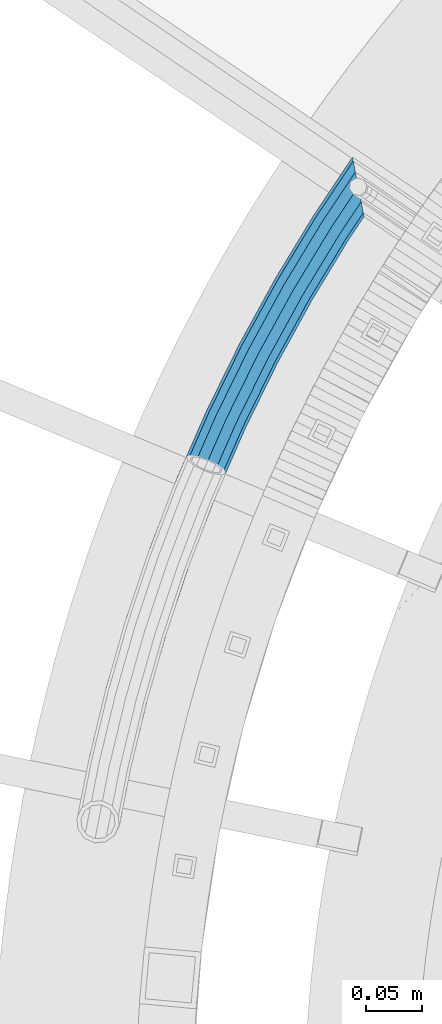
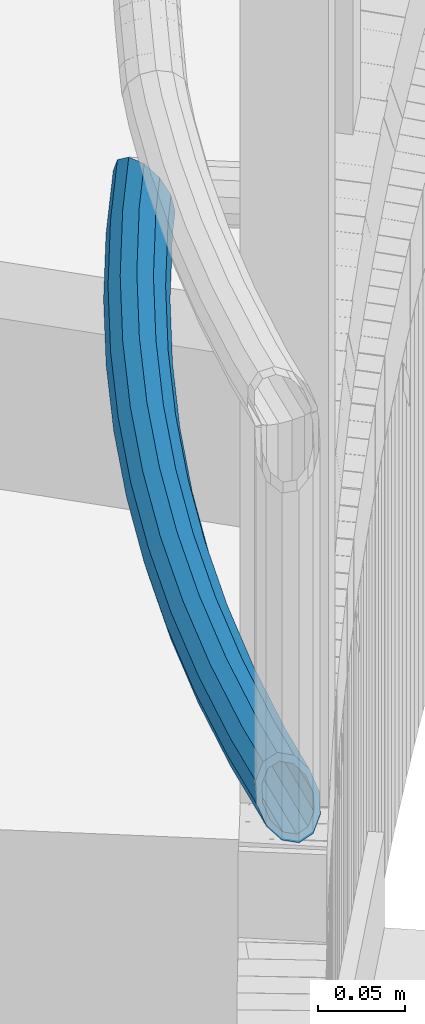
# One storey, part 477 of 975: 1 beam.
"""IFC2X3 building model written with IfcOpenShell, lengths in millimetres."""

import ifcopenshell
import ifcopenshell.guid

model = None  # the IFC model being written
_history = None  # IfcOwnerHistory: only IFC2X3 demands one
_inside = {}  # id of a spatial element -> (the spatial element, [elements in it])
_under = {}  # id of a project, library or spatial element -> (it, [spatial elements below it])
_declared = {}  # id of a project -> (the project, [libraries it declares])
_typed = {}  # id of a type object -> (the type object, [elements of that type])
_made_of = {}  # id of a material, layer set ... -> (it, [elements and type objects made of it])


def new_model(schema):
    """Start an empty IFC model of exactly this schema.

    Asked for "IFC4X3", IfcOpenShell would pick the latest addendum, in which some entities
    have other attributes; the version numbers below select the first issue.
    IFC2X3 requires an IfcOwnerHistory on every rooted entity: one is made here for all.
    """
    global model, _history
    if schema == "IFC4X3":
        model = ifcopenshell.file(schema_version=(4, 3, 0, 0))
    else:
        model = ifcopenshell.file(schema=schema)
    _inside.clear()
    _under.clear()
    _declared.clear()
    _typed.clear()
    _made_of.clear()
    _history = None
    if model.schema == "IFC2X3":
        org = make("IfcOrganization", Name="unknown")
        user = make(
            "IfcPersonAndOrganization",
            ThePerson=make("IfcPerson", FamilyName="unknown"),
            TheOrganization=org,
        )
        app = make(
            "IfcApplication",
            ApplicationDeveloper=org,
            Version="unknown",
            ApplicationFullName="unknown",
            ApplicationIdentifier="unknown",
        )
        _history = make(
            "IfcOwnerHistory",
            OwningUser=user,
            OwningApplication=app,
            ChangeAction="ADDED",
            CreationDate=0,
        )
    return model


def make(cls, **values):
    """One entity of the class cls with the attributes given. An attribute that is None is left unset."""
    return model.create_entity(
        cls, **{name: value for name, value in values.items() if value is not None}
    )


def rooted(cls, **values):
    """An entity with a GlobalId (a new one), such as an element, a storey or a relation."""
    return make(cls, GlobalId=ifcopenshell.guid.new(), OwnerHistory=_history, **values)


def si_unit(unit_type, name, prefix=None):
    """IfcSIUnit, for example si_unit("LENGTHUNIT", "METRE", prefix="MILLI")."""
    return make("IfcSIUnit", UnitType=unit_type, Prefix=prefix, Name=name)


def assignment(units):
    """IfcUnitAssignment: the units of a project."""
    return None if units is None else make("IfcUnitAssignment", Units=units)


def point(xyz):
    """IfcCartesianPoint."""
    return None if xyz is None else make("IfcCartesianPoint", Coordinates=xyz)


def direction(xyz):
    """IfcDirection."""
    return None if xyz is None else make("IfcDirection", DirectionRatios=xyz)


def frame(location, z_axis=None, x_axis=None):
    """IfcAxis2Placement3D, a coordinate frame: its origin and axes. An axis left out is left unset."""
    return make(
        "IfcAxis2Placement3D",
        Location=point(location),
        Axis=direction(z_axis),
        RefDirection=direction(x_axis),
    )


def origin_with_axes():
    """The frame at (0, 0, 0) with the z axis (0, 0, 1) and the x axis (1, 0, 0) written out."""
    return frame((0.0, 0.0, 0.0), z_axis=(0.0, 0.0, 1.0), x_axis=(1.0, 0.0, 0.0))


def place(relative_to, where):
    """IfcLocalPlacement: puts the frame where relative to a parent placement (None: the world)."""
    return make(
        "IfcLocalPlacement", PlacementRelTo=relative_to, RelativePlacement=where
    )


def context(
    kind, dimensions, precision=None, world=None, true_north=None, identifier=None
):
    """IfcGeometricRepresentationContext, for example the 3D "Model" context."""
    return make(
        "IfcGeometricRepresentationContext",
        ContextIdentifier=identifier,
        ContextType=kind,
        CoordinateSpaceDimension=dimensions,
        Precision=precision,
        WorldCoordinateSystem=world,
        TrueNorth=true_north,
    )


def subcontext(parent, identifier, kind, view, scale=None):
    """IfcGeometricRepresentationSubContext, for example "Body" below "Model"."""
    return make(
        "IfcGeometricRepresentationSubContext",
        ContextIdentifier=identifier,
        ContextType=kind,
        ParentContext=parent,
        TargetScale=scale,
        TargetView=view,
    )


def project(units=None, contexts=None):
    """IfcProject with its units and contexts."""
    return rooted(
        "IfcProject",
        Name="project",
        RepresentationContexts=contexts,
        UnitsInContext=assignment(units),
    )


def spatial(cls, under=None, at=None, **own):
    """A site, building, storey or space (cls), placed at a placement, below another one or the project."""
    s = rooted(cls, ObjectPlacement=at, **own)
    if under is not None:
        _under.setdefault(under.id(), (under, []))[1].append(s)
    return s


def faces_of(points, faces, orient=None, outer=None):
    """IfcFace entities. A face is a list of loops; a loop is a list of indices into points, from 0.

    orient and outer hold one flag for each loop. By default every Orientation is true, the
    first loop of a face is its IfcFaceOuterBound and the others are IfcFaceBound.
    """
    made = []
    for i, loops in enumerate(faces):
        bounds = []
        for j, loop in enumerate(loops):
            is_outer = j == 0 if outer is None else outer[i][j]
            bounds.append(
                make(
                    "IfcFaceOuterBound" if is_outer else "IfcFaceBound",
                    Bound=make("IfcPolyLoop", Polygon=[points[k] for k in loop]),
                    Orientation=True if orient is None else orient[i][j],
                )
            )
        made.append(make("IfcFace", Bounds=bounds))
    return made


def faceted_brep(points, faces, orient=None, outer=None, voids=None):
    """IfcFacetedBrep: a solid bounded by flat faces; with voids (closed shells), ...WithVoids."""
    shared = [point(p) for p in points]
    hull = make("IfcClosedShell", CfsFaces=faces_of(shared, faces, orient, outer))
    if voids is None:
        return make("IfcFacetedBrep", Outer=hull)
    return make(
        "IfcFacetedBrepWithVoids",
        Outer=hull,
        Voids=[
            make(cls, CfsFaces=faces_of(shared, fs, o, b)) for cls, fs, o, b in voids
        ],
    )


def shape(context_of_items, identifier, shape_type, items):
    """IfcShapeRepresentation: the items that make up one representation, for example the "Body"."""
    return make(
        "IfcShapeRepresentation",
        ContextOfItems=context_of_items,
        RepresentationIdentifier=identifier,
        RepresentationType=shape_type,
        Items=items,
    )


def material(Name=None, Category=None):
    """IfcMaterial."""
    return make("IfcMaterial", Name=Name, Category=Category)


def made_of(thing, what):
    """Note that an element or type object is made of a material, layer set ...; save() writes the relation."""
    if what is not None:
        _made_of.setdefault(what.id(), (what, []))[1].append(thing)
    return thing


def type_object(cls, material=None, **own):
    """A type object (cls), such as IfcWallType, which elements share."""
    return made_of(rooted(cls, **own), material)


def element(
    cls,
    number,
    at=None,
    inside=None,
    cuts=None,
    type_object=None,
    material=None,
    context=None,
    identifier="Body",
    shape_type=None,
    held_by="IfcProductDefinitionShape",
    body=None,
    shapes=None,
    **own,
):
    """One element of the class cls, such as IfcWall. Its Tag is "e" and its number.

    at: its placement. inside: the storey or other place that contains it. cuts: it is an
    opening in that element (IfcRelVoidsElement). A single representation is given by context,
    identifier, shape_type and body (its items); several are given by shapes. held_by: the class
    of the entity that holds the representations. save() writes the other relations.
    """
    e = rooted(cls, Tag="e%d" % number, ObjectPlacement=at, **own)
    if body is not None:
        shapes = [shape(context, identifier, shape_type, body)]
    if shapes is not None:
        e.Representation = make(held_by, Representations=shapes)
    if inside is not None:
        _inside.setdefault(inside.id(), (inside, []))[1].append(e)
    if cuts is not None:
        rooted(
            "IfcRelVoidsElement", RelatingBuildingElement=cuts, RelatedOpeningElement=e
        )
    if type_object is not None:
        _typed.setdefault(type_object.id(), (type_object, []))[1].append(e)
    return made_of(e, material)


def aggregate(whole, parts):
    """IfcRelAggregates: a whole, such as a stair, and the parts it consists of."""
    return rooted("IfcRelAggregates", RelatingObject=whole, RelatedObjects=parts)


def save(model, path):
    """Write the relations noted so far, then the file.

    IfcRelAggregates (storeys below a building ...), IfcRelContainedInSpatialStructure (elements
    in a storey), IfcRelDefinesByType, IfcRelAssociatesMaterial and IfcRelDeclares: one each for
    every whole, place, type object, material and project.
    """
    for whole, parts in _under.values():
        aggregate(whole, parts)
    for where, things in _inside.values():
        rooted(
            "IfcRelContainedInSpatialStructure",
            RelatedElements=things,
            RelatingStructure=where,
        )
    for kind, things in _typed.values():
        rooted("IfcRelDefinesByType", RelatedObjects=things, RelatingType=kind)
    for what, things in _made_of.values():
        rooted("IfcRelAssociatesMaterial", RelatedObjects=things, RelatingMaterial=what)
    for by, libraries in _declared.values():
        rooted("IfcRelDeclares", RelatingContext=by, RelatedDefinitions=libraries)
    model.write(path)


model = new_model("IFC2X3")

# Units and contexts
model_context = context("Model", 3, precision=1e-05, world=origin_with_axes())
body_context = subcontext(model_context, "Body", "Model", "MODEL_VIEW")
ifc_project = project(units=[si_unit("LENGTHUNIT", "METRE", prefix="MILLI"), si_unit("AREAUNIT", "SQUARE_METRE"), si_unit("VOLUMEUNIT", "CUBIC_METRE"), si_unit("MASSUNIT", "GRAM", prefix="KILO"), si_unit("TIMEUNIT", "SECOND"), si_unit("PLANEANGLEUNIT", "RADIAN"), si_unit("SOLIDANGLEUNIT", "STERADIAN"), si_unit("THERMODYNAMICTEMPERATUREUNIT", "DEGREE_CELSIUS"), si_unit("LUMINOUSINTENSITYUNIT", "LUMEN")], contexts=[model_context])

# Site, building, storey
site_placement = place(None, origin_with_axes())
site = spatial("IfcSite", under=ifc_project, at=site_placement, CompositionType="ELEMENT")
building_placement = place(site_placement, origin_with_axes())
building = spatial("IfcBuilding", under=site, at=building_placement, Name="Undefined", CompositionType="ELEMENT")
storey_placement = place(building_placement, origin_with_axes())
storey = spatial("IfcBuildingStorey", under=building, at=storey_placement, Name="Undefined", CompositionType="ELEMENT", Elevation=0.0)

# Beam
ifc_material = material()
beam_type = type_object("IfcBeamType", PredefinedType="NOTDEFINED")
beam_placement = place(storey_placement, frame((33276.7534098657, 3656.66738124268, 628.65), z_axis=(-0.924359056186259, 0.381523702076881, 0.0), x_axis=(0.381523702076881, 0.924359056186259, 0.0)))
element("IfcBeam", 1, at=beam_placement, inside=storey, type_object=beam_type, material=ifc_material, Name="HANDRAIL", context=body_context, shape_type="Brep", body=[
    faceted_brep([(65.3637888262547, -16.4977839420935, 3.38205051437035), (66.5828862283506, -9.52499999999998, -3.48333493930113), (130.064114738725, -9.52499999999998, 6.35599401342552), (129.147726991516, -16.4977839420935, 13.2682982168153), (193.916236107083, -9.52499999999998, 13.3976816084796), (193.304326613952, -16.4977839420935, 20.3435640344615), (258.016017771459, -9.52499999999998, 17.62813761289), (257.709767498247, -16.4977839420935, 24.5941929294677), (322.239749193384, -9.52499999999998, 19.0391973812475), (322.239749193373, -16.4977839420935, 26.0119813233578), (386.463480615312, -9.52499999999998, 17.6281376130864), (386.769730888507, -16.4977839420935, 24.5941929296569), (450.563262279695, -9.52499999999998, 13.3976816088543), (451.175171772811, -16.4977839420935, 20.3435640348325), (514.415383648073, -9.52499999999998, 6.3559940139894), (515.331771395264, -16.4977839420935, 13.2682982173792), (577.896612158471, -9.52499999999998, -3.48333493855534), (579.115709560549, -16.4977839420935, 3.38205051512705), (514.079962452885, 0.0, 3.82591507686448), (577.450391539624, 0.0, -5.99624042137293), (450.339287860399, 0.0, 10.8553121892437), (386.351385235408, 0.0, 15.0783844030484), (322.239749193384, 0.0, 16.4869813233345), (258.128113151368, 0.0, 15.0783844028665), (194.140210526388, 0.0, 10.8553121888654), (130.399535933917, 0.0, 3.82591507630787), (67.0291068472052, 0.0, -5.99624042211872), (66.5828862283506, 9.52499999999998, -3.48333493930113), (130.064114738725, 9.52499999999998, 6.35599401342552), (193.916236107083, 9.52499999999998, 13.3976816084796), (258.016017771459, 9.52499999999998, 17.62813761289), (322.239749193384, 9.52499999999998, 19.0391973812475), (386.463480615312, 9.52499999999998, 17.6281376130864), (450.563262279695, 9.52499999999998, 13.3976816088543), (514.415383648073, 9.52499999999998, 6.3559940139894), (577.896612158471, 9.52499999999998, -3.48333493855534), (515.331771395264, 16.4977839420935, 13.2682982173792), (579.115709560549, 16.4977839420935, 3.38205051512705), (451.175171772811, 16.4977839420935, 20.3435640348325), (386.769730888507, 16.4977839420935, 24.5941929296569), (322.239749193373, 16.4977839420935, 26.0119813233578), (257.709767498247, 16.4977839420935, 24.5941929294677), (193.304326613952, 16.4977839420935, 20.3435640344615), (129.147726991516, 16.4977839420935, 13.2682982168153), (65.3637888262547, 16.4977839420935, 3.38205051437035), (2.63382389675826e-07, 19.0500000000138, 0.0), (-2.07561308872391, 16.4977839420935, 9.29609892945882), (62.0331527843518, 16.4977839420935, 22.1386323873594), (63.6984708053005, 19.05, 12.7603414508667), (2.07561308872391, 16.4977839420935, -9.29609892945882), (127.895918049117, 19.05, 22.7106813573264), (192.468442701516, 19.05, 29.8318158800575), (257.291421845126, 19.05, 34.1100014560689), (322.239749193363, 19.05, 35.5369813233847), (387.188076541603, 19.05, 34.1100014562617), (452.011055685223, 19.05, 29.8318158804359), (516.583580337643, 19.05, 22.7106813578939), (580.781027581477, 19.05, 12.760341451627), (517.835389280019, 16.4977839420935, 32.1530644984086), (582.44634560241, 16.4977839420935, 22.1386323881234), (452.846939597635, 16.4977839420935, 39.3200677260247), (387.606422194698, 16.4977839420935, 43.6258099828665), (322.239749193352, 16.4977839420935, 45.061981323408), (256.873076192007, 16.4977839420935, 43.62580998267), (191.632558789082, 16.4977839420935, 39.3200677256427), (126.644109106714, 16.4977839420935, 32.1530644978302), (60.8140553822523, 9.52499999999998, 29.0040178410381), (125.727721359504, 9.52499999999998, 39.06536870122), (191.020649295948, 9.52499999999998, 46.2659501516282), (256.566825918795, 9.52499999999998, 50.5918652992441), (322.239749193341, 9.52499999999998, 52.0347652655219), (387.912672467894, 9.52499999999998, 50.5918652994369), (453.458849090748, 9.52499999999998, 46.2659501520102), (518.751777027213, 9.52499999999998, 39.0653687017912), (583.665443004487, 9.52499999999998, 29.0040178418058), (519.087198222398, 0.0, 41.5954476389234), (584.111663623338, 0.0, 31.5169233246233), (453.682823510044, 0.0, 48.8083195716245), (388.024767847797, 0.0, 53.1416185094749), (322.239749193341, 0.0, 54.5869813234276), (256.454730538882, 0.0, 53.1416185092821), (190.796674876647, 0.0, 48.8083195712388), (125.392300164309, 0.0, 41.5954476383449), (60.3678347633977, 0.0, 31.5169233238521), (60.8140553822523, -9.52499999999998, 29.0040178410381), (125.727721359504, -9.52499999999998, 39.06536870122), (191.020649295948, -9.52499999999998, 46.2659501516282), (256.566825918795, -9.52499999999998, 50.5918652992441), (322.239749193341, -9.52499999999998, 52.0347652655219), (387.912672467894, -9.52499999999998, 50.5918652994369), (453.458849090748, -9.52499999999998, 46.2659501520102), (518.751777027213, -9.52499999999998, 39.0653687017912), (583.665443004487, -9.52499999999998, 29.0040178418058), (517.835389280019, -16.4977839420935, 32.1530644984086), (582.44634560241, -16.4977839420935, 22.1386323881234), (452.846939597635, -16.4977839420935, 39.3200677260247), (387.606422194698, -16.4977839420935, 43.6258099828665), (322.239749193352, -16.4977839420935, 45.061981323408), (256.873076192007, -16.4977839420935, 43.62580998267), (191.632558789082, -16.4977839420935, 39.3200677256427), (126.644109106714, -16.4977839420935, 32.1530644978302), (62.0331527843518, -16.4977839420935, 22.1386323873594), (63.6984708053005, -19.05, 12.7603414508667), (127.895918049117, -19.05, 22.7106813573264), (192.468442701516, -19.05, 29.8318158800575), (257.291421845126, -19.05, 34.1100014560689), (322.239749193363, -19.05, 35.5369813233847), (387.188076541603, -19.05, 34.1100014562617), (452.011055685223, -19.05, 29.8318158804359), (516.583580337643, -19.05, 22.7106813578939), (580.781027581477, -19.05, 12.760341451627), (623.525097919031, -19.05, 4.19767227600096), (634.804402413814, -16.4977839420935, 11.6500496299996), (643.061426378037, -9.52499999999998, 17.1055684903004), (646.083706908601, 0.0, 19.1024269839945), (643.061426378037, 9.52499999999998, 17.1055684903004), (634.804402413814, 16.4977839420935, 11.6500496299996), (623.525097919031, 19.05, 4.19767227600096), (612.245793424245, 16.4977839420935, -3.254705077994), (603.988769460022, 9.52499999999998, -8.7102239382948), (600.966488929462, 0.0, -10.7070824319962), (603.988769460022, -9.52499999999998, -8.7102239382948), (612.245793424245, -16.4977839420935, -3.254705077994), (30.790975576012, -19.05, 6.16817573464141), (30.3241337357649, -16.4977839420935, -3.63723829465016), (24.9767879872525, -9.52499999999998, -11.8180408322805), (16.181755305437, 0.0, -16.1821924448705), (6.29565759481557, 9.52499999999998, -15.5603222321697), (2.99239702710111, 12.2906573535938, -13.402121499068), (-1.99318286347625, 16.4977839420935, -10.2988858246208), (-6.50834134794059, 19.05, -1.60403212389792), (-6.06585272390294, 16.4977839420935, 8.3126728590214), (-2.96709431060299, 12.4067716602382, 13.2887976059719), (-0.757097620109562, 9.52499999999998, 16.6698295018068), (8.0379350617095, 0.0, 21.0339811143895), (17.924032772331, -9.52499999999998, 20.4121109016887), (26.2522236139012, -16.4977839420935, 14.9708484849871), (1.67432789157101, 13.3082123799554, -7.49885313643608), (0.710976735876102, 13.3082123799554, -7.73627863667934), (1.89139084506678, 12.3121092799737, -8.47101827673396), (2.12461600312963e-07, 15.3670000000093, 0.0), (-2.93125110825531, 15.367, -0.722429984769406), (-1.67432789157465, 13.3082123799554, 7.49885313643244), (-1.8753978715722, 12.3855011242308, 8.39939015654454), (-2.57431028486826, 13.3082123799554, 7.27704536812598), (63.6984708053005, 15.367, 12.7603414508667), (62.3551142684009, 13.3082123799554, 20.3254961396378), (61.3717090307091, 7.68349999999998, 25.8635737389341), (1.73051132193723, 7.68349999999998, 13.9160020361778), (61.0117577314977, 0.0, 27.890650828409), (8.82517101860321, 0.0, 17.4364176703311), (61.3717090307091, -7.68349999999998, 25.8635737389341), (16.7999565051687, -7.68349999999998, 16.9347756987518), (62.3551142684009, -13.3082123799554, 20.3254961396378), (23.5180304507048, -13.3082123799554, 12.5454906826089), (63.6984708053005, -15.367, 12.7603414508667), (27.1792903668047, -15.367, 5.44466799733345), (66.3851838791052, 0.0, -2.36996792668288), (66.0252325798974, 7.68349999999998, -0.342890837204322), (7.41973386197424, 7.68349999999998, -12.0829870292255), (15.3945193485433, 0.0, -12.5846290008121), (66.0252325798974, -7.68349999999998, -0.342890837204322), (22.4891790452093, -7.68349999999998, -9.06421336665517), (65.0418273422038, -13.3082123799554, 5.19518676209191), (26.8027046156749, -13.3082123799554, -2.46503265296269), (65.0418273422038, 13.3082123799554, 5.19518676209191), (128.905710595986, 13.3082123799554, 15.0938256239788), (127.895918049117, 15.367, 22.7106813573264), (126.886125502246, 13.3082123799554, 30.3275370906704), (126.146906052829, 7.68349999999998, 35.9034624814012), (125.876332955373, 0.0, 37.9443928240107), (126.146906052829, -7.68349999999998, 35.9034624814012), (126.886125502246, -13.3082123799554, 30.3275370906704), (127.895918049117, -15.367, 22.7106813573264), (128.905710595986, -13.3082123799554, 15.0938256239788), (129.644930045401, -7.68349999999998, 9.51790023324793), (129.915503142856, 0.0, 7.47696989063479), (129.644930045401, 7.68349999999998, 9.51790023324793), (193.636329382009, 7.68349999999998, 16.5749475676494), (193.142722390881, 13.3082123799554, 22.1779593912761), (192.468442701516, 15.367, 29.8318158800575), (191.794163012153, 13.3082123799554, 37.4856723688281), (191.300556021026, 7.68349999999998, 43.0886841924548), (191.11988332279, 0.0, 45.1395288576059), (191.300556021026, -7.68349999999998, 43.0886841924548), (191.794163012153, -13.3082123799554, 37.4856723688281), (192.468442701516, -15.367, 29.8318158800575), (193.142722390881, -13.3082123799554, 22.1779593912761), (193.636329382009, -7.68349999999998, 16.5749475676494), (193.817002080246, 0.0, 14.5241029024946), (257.96635283216, 0.0, 18.7578303664886), (257.875929225702, 7.68349999999998, 20.8146312892422), (257.628887338644, 13.3082123799554, 26.4339159112751), (257.291421845126, 15.367, 34.1100014560689), (256.953956351608, 13.3082123799554, 41.7860870008662), (256.70691446455, 7.68349999999998, 47.4053716228991), (256.61649085809, 0.0, 49.46217254566), (256.70691446455, -7.68349999999998, 47.4053716228991), (256.953956351608, -13.3082123799554, 41.7860870008662), (257.291421845126, -15.367, 34.1100014560689), (257.628887338644, -13.3082123799554, 26.4339159112751), (257.875929225702, -7.68349999999998, 20.8146312892422), (322.239749193381, -7.68349999999998, 22.2287689433906), (322.239749193381, 0.0, 20.1699813233427), (322.239749193381, 7.68349999999998, 22.2287689433906), (322.239749193373, 13.3082123799554, 27.8534813233637), (322.239749193363, 15.367, 35.5369813233847), (322.239749193355, 13.3082123799554, 43.2204813233984), (322.239749193344, 7.68349999999998, 48.8451937033751), (322.239749193344, 0.0, 50.9039813234194), (322.239749193344, -7.68349999999998, 48.8451937033751), (322.239749193355, -13.3082123799554, 43.2204813233984), (322.239749193363, -15.367, 35.5369813233847), (322.239749193373, -13.3082123799554, 27.8534813233637), (386.850611048107, -13.3082123799554, 26.4339159114606), (386.60356916106, -7.68349999999998, 20.8146312894351), (386.513145554607, 0.0, 18.7578303666705), (386.60356916106, 7.68349999999998, 20.8146312894351), (386.850611048107, 13.3082123799554, 26.4339159114606), (387.188076541603, 15.367, 34.1100014562617), (387.525542035102, 13.3082123799554, 41.7860870010554), (387.772583922142, 7.68349999999998, 47.4053716230883), (387.863007528602, 0.0, 49.4621725458528), (387.772583922142, -7.68349999999998, 47.4053716230883), (387.525542035102, -13.3082123799554, 41.7860870010554), (387.188076541603, -15.367, 34.1100014562617), (452.011055685223, -15.367, 29.8318158804359), (451.336775995878, -13.3082123799554, 22.1779593916544), (450.843169004766, -7.68349999999998, 16.5749475680241), (450.66249630653, 0.0, 14.524102902873), (450.843169004766, 7.68349999999998, 16.5749475680241), (451.336775995878, 13.3082123799554, 22.1779593916544), (452.011055685223, 15.367, 29.8318158804359), (452.685335374568, 13.3082123799554, 37.4856723692101), (453.178942365681, 7.68349999999998, 43.0886841928404), (453.359615063913, 0.0, 45.1395288579915), (453.178942365681, -7.68349999999998, 43.0886841928404), (452.685335374568, -13.3082123799554, 37.4856723692101), (517.593372884494, -13.3082123799554, 30.3275370912379), (516.583580337643, -15.367, 22.7106813578939), (515.573787790792, -13.3082123799554, 15.0938256245427), (514.83456834139, -7.68349999999998, 9.51790023381545), (514.563995243938, 0.0, 7.47696989119868), (514.83456834139, 7.68349999999998, 9.51790023381545), (515.573787790792, 13.3082123799554, 15.0938256245427), (516.583580337643, 15.367, 22.7106813578939), (517.593372884494, 13.3082123799554, 30.3275370912379), (518.332592333896, 7.68349999999998, 35.9034624819724), (518.603165431345, 0.0, 37.9443928245892), (518.332592333896, -7.68349999999998, 35.9034624819724), (583.10778935604, -7.68349999999998, 25.8635737397053), (582.124384118364, -13.3082123799554, 20.3254961404018), (580.781027581477, -15.367, 12.760341451627), (579.437671044598, -13.3082123799554, 5.19518676284861), (578.454265806919, -7.68349999999998, -0.342890836451261), (578.094314507714, 0.0, -2.36996792592618), (578.454265806919, 7.68349999999998, -0.342890836451261), (579.437671044598, 13.3082123799554, 5.19518676284861), (580.781027581477, 15.367, 12.760341451627), (582.124384118364, 13.3082123799554, 20.3254961404018), (583.10778935604, 7.68349999999998, 25.8635737397053), (583.467740655247, 0.0, 27.8906508291766), (641.722375837286, 0.0, 16.2208410737876), (639.284402875965, -7.68349999999998, 14.6100418888745), (632.623736878159, -13.3082123799554, 10.2092566748906), (623.525097919031, -15.367, 4.19767227600096), (614.426458959904, -13.3082123799554, -1.81391212288509), (607.765792962098, -7.68349999999998, -6.21469733686536), (605.327820000777, 0.0, -7.8254965217784), (607.765792962098, 7.68349999999998, -6.21469733686536), (614.426458959904, 13.3082123799554, -1.81391212288509), (623.525097919031, 15.367, 4.19767227600096), (632.623736878159, 13.3082123799554, 10.2092566748906), (639.284402875965, 7.68349999999998, 14.6100418888745)], [[[0, 1, 2, 3]], [[3, 2, 4, 5]], [[5, 4, 6, 7]], [[7, 6, 8, 9]], [[9, 8, 10, 11]], [[11, 10, 12, 13]], [[13, 12, 14, 15]], [[15, 14, 16, 17]], [[14, 18, 19, 16]], [[12, 20, 18, 14]], [[10, 21, 20, 12]], [[8, 22, 21, 10]], [[6, 23, 22, 8]], [[4, 24, 23, 6]], [[2, 25, 24, 4]], [[1, 26, 25, 2]], [[26, 27, 28, 25]], [[25, 28, 29, 24]], [[24, 29, 30, 23]], [[23, 30, 31, 22]], [[22, 31, 32, 21]], [[21, 32, 33, 20]], [[20, 33, 34, 18]], [[18, 34, 35, 19]], [[34, 36, 37, 35]], [[33, 38, 36, 34]], [[32, 39, 38, 33]], [[31, 40, 39, 32]], [[30, 41, 40, 31]], [[29, 42, 41, 30]], [[28, 43, 42, 29]], [[27, 44, 43, 28]], [[45, 46, 47, 48]], [[49, 45, 48, 44]], [[44, 48, 50, 43]], [[43, 50, 51, 42]], [[42, 51, 52, 41]], [[41, 52, 53, 40]], [[40, 53, 54, 39]], [[39, 54, 55, 38]], [[38, 55, 56, 36]], [[36, 56, 57, 37]], [[56, 58, 59, 57]], [[55, 60, 58, 56]], [[54, 61, 60, 55]], [[53, 62, 61, 54]], [[52, 63, 62, 53]], [[51, 64, 63, 52]], [[50, 65, 64, 51]], [[48, 47, 65, 50]], [[47, 66, 67, 65]], [[65, 67, 68, 64]], [[64, 68, 69, 63]], [[63, 69, 70, 62]], [[62, 70, 71, 61]], [[61, 71, 72, 60]], [[60, 72, 73, 58]], [[58, 73, 74, 59]], [[73, 75, 76, 74]], [[72, 77, 75, 73]], [[71, 78, 77, 72]], [[70, 79, 78, 71]], [[69, 80, 79, 70]], [[68, 81, 80, 69]], [[67, 82, 81, 68]], [[66, 83, 82, 67]], [[83, 84, 85, 82]], [[82, 85, 86, 81]], [[81, 86, 87, 80]], [[80, 87, 88, 79]], [[79, 88, 89, 78]], [[78, 89, 90, 77]], [[77, 90, 91, 75]], [[75, 91, 92, 76]], [[91, 93, 94, 92]], [[90, 95, 93, 91]], [[89, 96, 95, 90]], [[88, 97, 96, 89]], [[87, 98, 97, 88]], [[86, 99, 98, 87]], [[85, 100, 99, 86]], [[84, 101, 100, 85]], [[101, 102, 103, 100]], [[100, 103, 104, 99]], [[99, 104, 105, 98]], [[98, 105, 106, 97]], [[97, 106, 107, 96]], [[96, 107, 108, 95]], [[95, 108, 109, 93]], [[93, 109, 110, 94]], [[94, 110, 111, 112]], [[92, 94, 112, 113]], [[76, 92, 113, 114]], [[74, 76, 114, 115]], [[59, 74, 115, 116]], [[57, 59, 116, 117]], [[37, 57, 117, 118]], [[35, 37, 118, 119]], [[19, 35, 119, 120]], [[16, 19, 120, 121]], [[17, 16, 121, 122]], [[110, 17, 122, 111]], [[109, 15, 17, 110]], [[108, 13, 15, 109]], [[107, 11, 13, 108]], [[106, 9, 11, 107]], [[105, 7, 9, 106]], [[104, 5, 7, 105]], [[103, 3, 5, 104]], [[102, 0, 3, 103]], [[0, 102, 123, 124]], [[1, 0, 124, 125]], [[26, 1, 125, 126]], [[27, 26, 126, 127]], [[49, 44, 27, 127, 128]], [[49, 128, 129]], [[45, 49, 129, 130]], [[46, 45, 130, 131]], [[46, 131, 132]], [[66, 47, 46, 132, 133]], [[83, 66, 133, 134]], [[84, 83, 134, 135]], [[101, 84, 135, 136]], [[102, 101, 136, 123]], [[137, 138, 139]], [[137, 140, 141, 138]], [[142, 143, 144]], [[140, 142, 144, 141]], [[142, 140, 145, 146]], [[142, 146, 147, 148, 143]], [[147, 149, 150, 148]], [[149, 151, 152, 150]], [[151, 153, 154, 152]], [[153, 155, 156, 154]], [[157, 158, 159, 160]], [[161, 157, 160, 162]], [[163, 161, 162, 164]], [[155, 163, 164, 156]], [[135, 134, 133, 132, 131, 130, 129, 128, 127, 126, 125, 124, 123, 136], [162, 160, 159, 139, 138, 141, 144, 143, 148, 150, 152, 154, 156, 164]], [[158, 165, 137, 139, 159]], [[140, 137, 165, 145]], [[145, 165, 166, 167]], [[146, 145, 167, 168]], [[147, 146, 168, 169]], [[149, 147, 169, 170]], [[151, 149, 170, 171]], [[153, 151, 171, 172]], [[155, 153, 172, 173]], [[163, 155, 173, 174]], [[161, 163, 174, 175]], [[157, 161, 175, 176]], [[158, 157, 176, 177]], [[165, 158, 177, 166]], [[166, 177, 178, 179]], [[167, 166, 179, 180]], [[168, 167, 180, 181]], [[169, 168, 181, 182]], [[170, 169, 182, 183]], [[171, 170, 183, 184]], [[172, 171, 184, 185]], [[173, 172, 185, 186]], [[174, 173, 186, 187]], [[175, 174, 187, 188]], [[176, 175, 188, 189]], [[177, 176, 189, 178]], [[178, 189, 190, 191]], [[179, 178, 191, 192]], [[180, 179, 192, 193]], [[181, 180, 193, 194]], [[182, 181, 194, 195]], [[183, 182, 195, 196]], [[184, 183, 196, 197]], [[185, 184, 197, 198]], [[186, 185, 198, 199]], [[187, 186, 199, 200]], [[188, 187, 200, 201]], [[189, 188, 201, 190]], [[190, 201, 202, 203]], [[191, 190, 203, 204]], [[192, 191, 204, 205]], [[193, 192, 205, 206]], [[194, 193, 206, 207]], [[195, 194, 207, 208]], [[196, 195, 208, 209]], [[197, 196, 209, 210]], [[198, 197, 210, 211]], [[199, 198, 211, 212]], [[200, 199, 212, 213]], [[201, 200, 213, 202]], [[202, 213, 214, 215]], [[203, 202, 215, 216]], [[204, 203, 216, 217]], [[205, 204, 217, 218]], [[206, 205, 218, 219]], [[207, 206, 219, 220]], [[208, 207, 220, 221]], [[209, 208, 221, 222]], [[210, 209, 222, 223]], [[211, 210, 223, 224]], [[212, 211, 224, 225]], [[213, 212, 225, 214]], [[214, 225, 226, 227]], [[215, 214, 227, 228]], [[216, 215, 228, 229]], [[217, 216, 229, 230]], [[218, 217, 230, 231]], [[219, 218, 231, 232]], [[220, 219, 232, 233]], [[221, 220, 233, 234]], [[222, 221, 234, 235]], [[223, 222, 235, 236]], [[224, 223, 236, 237]], [[225, 224, 237, 226]], [[226, 237, 238, 239]], [[227, 226, 239, 240]], [[228, 227, 240, 241]], [[229, 228, 241, 242]], [[230, 229, 242, 243]], [[231, 230, 243, 244]], [[232, 231, 244, 245]], [[233, 232, 245, 246]], [[234, 233, 246, 247]], [[235, 234, 247, 248]], [[236, 235, 248, 249]], [[237, 236, 249, 238]], [[238, 249, 250, 251]], [[239, 238, 251, 252]], [[240, 239, 252, 253]], [[241, 240, 253, 254]], [[242, 241, 254, 255]], [[243, 242, 255, 256]], [[244, 243, 256, 257]], [[245, 244, 257, 258]], [[246, 245, 258, 259]], [[247, 246, 259, 260]], [[248, 247, 260, 261]], [[249, 248, 261, 250]], [[250, 261, 262, 263]], [[251, 250, 263, 264]], [[252, 251, 264, 265]], [[253, 252, 265, 266]], [[254, 253, 266, 267]], [[255, 254, 267, 268]], [[256, 255, 268, 269]], [[257, 256, 269, 270]], [[258, 257, 270, 271]], [[259, 258, 271, 272]], [[260, 259, 272, 273]], [[261, 260, 273, 262]], [[112, 111, 122, 121, 120, 119, 118, 117, 116, 115, 114, 113], [272, 271, 270, 269, 268, 267, 266, 265, 264, 263, 262, 273]]]),
])

save(model, "model.ifc")
